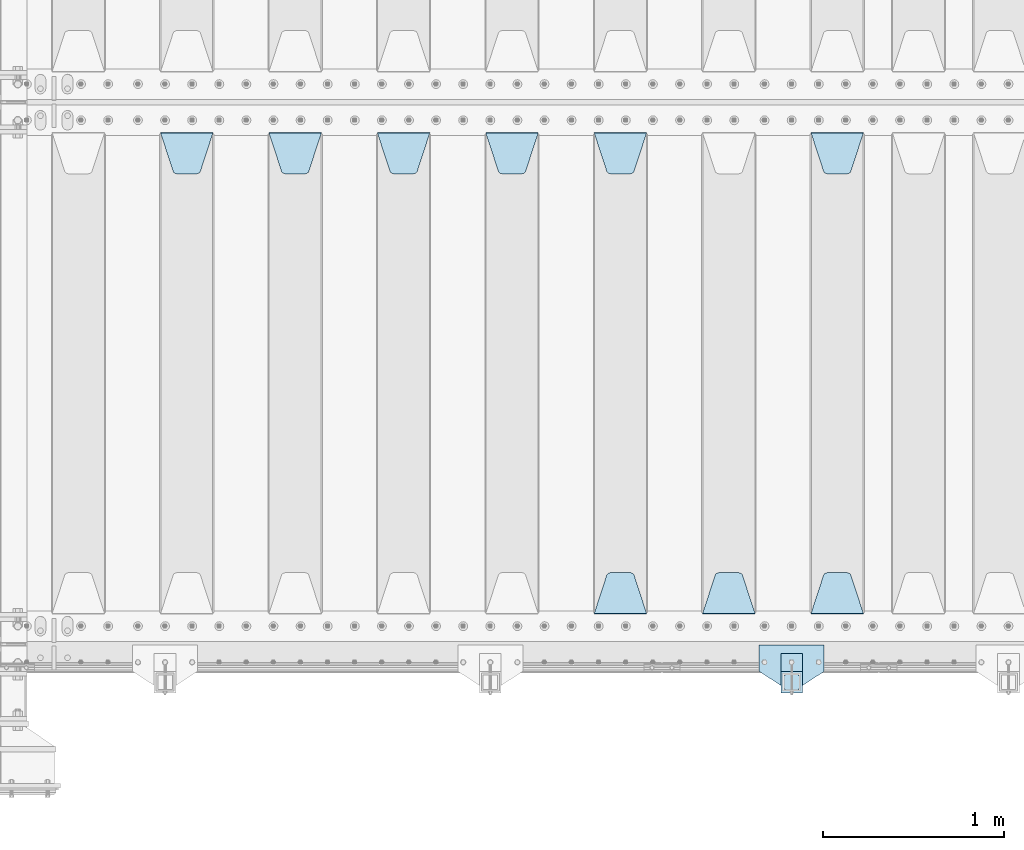
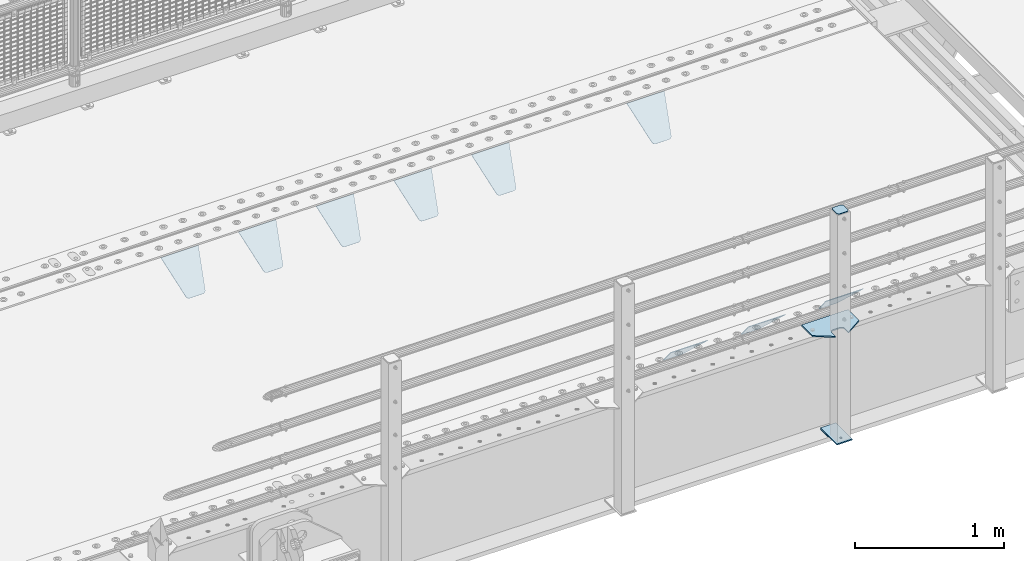
# One storey, part 218 of 242: 13 plates.
"""IFC2X3 building model written with IfcOpenShell, lengths in millimetres."""

from ifc_helpers import new_model, si_unit, frame, origin_with_axes, place, context, subcontext, project, spatial, faceted_brep, material, type_object, element, save


model = new_model("IFC2X3")

# Units and contexts
model_context = context("Model", 3, precision=1e-05, world=origin_with_axes())
body_context = subcontext(model_context, "Body", "Model", "MODEL_VIEW")
ifc_project = project(units=[si_unit("LENGTHUNIT", "METRE", prefix="MILLI"), si_unit("AREAUNIT", "SQUARE_METRE"), si_unit("VOLUMEUNIT", "CUBIC_METRE"), si_unit("MASSUNIT", "GRAM", prefix="KILO"), si_unit("TIMEUNIT", "SECOND"), si_unit("PLANEANGLEUNIT", "RADIAN"), si_unit("SOLIDANGLEUNIT", "STERADIAN"), si_unit("THERMODYNAMICTEMPERATUREUNIT", "DEGREE_CELSIUS"), si_unit("LUMINOUSINTENSITYUNIT", "LUMEN")], contexts=[model_context])

# Site, building, storey
site_placement = place(None, origin_with_axes())
site = spatial("IfcSite", under=ifc_project, at=site_placement, CompositionType="ELEMENT")
building_placement = place(site_placement, origin_with_axes())
building = spatial("IfcBuilding", under=site, at=building_placement, Name="Standard", CompositionType="ELEMENT")
storey_placement = place(building_placement, origin_with_axes())
storey = spatial("IfcBuildingStorey", under=building, at=storey_placement, Name="Undefined", CompositionType="ELEMENT", Elevation=0.0)

# Plates
ifc_material_1 = material(Name="STEEL/S355J2")
plate_type_1 = type_object("IfcPlateType", PredefinedType="NOTDEFINED")
plate_1_placement = place(storey_placement, frame((-23852.0, -24005.0, 5.00000000004911), z_axis=(0.0, -1.0, 0.0), x_axis=(-1.0, 0.0, 0.0)))
element("IfcPlate", 1, at=plate_1_placement, inside=storey, type_object=plate_type_1, material=ifc_material_1, context=body_context, shape_type="Brep", body=[
    faceted_brep([(0.0, -5.0, 0.0), (2.31396552408114e-06, -5.0, 145.0), (2.31396552408114e-06, 5.0, 145.0), (0.0, 5.0, 0.0), (130.0, -5.0, 230.0), (130.0, 5.0, 230.0), (130.0, -5.0, 180.0), (130.0, 5.0, 180.0), (130.48036798992, -5.0, 175.122741949595), (130.48036798992, 5.0, 175.122741949595), (131.903011687216, -5.0, 170.432914190871), (131.903011687216, 5.0, 170.432914190871), (134.213259692435, -5.0, 166.110744174512), (134.213259692435, 5.0, 166.110744174512), (137.322330470335, -5.0, 162.322330470335), (137.322330470335, 5.0, 162.322330470335), (141.110744174512, -5.0, 159.213259692435), (141.110744174512, 5.0, 159.213259692435), (145.432914190871, -5.0, 156.903011687216), (145.432914190871, 5.0, 156.903011687216), (150.122741949595, -5.0, 155.48036798992), (150.122741949595, 5.0, 155.48036798992), (155.0, -5.0, 155.0), (155.0, 5.0, 155.0), (205.0, -5.0, 155.0), (205.0, 5.0, 155.0), (209.877258050405, -5.0, 155.48036798992), (209.877258050405, 5.0, 155.48036798992), (214.567085809129, -5.0, 156.903011687216), (214.567085809129, 5.0, 156.903011687216), (218.889255825488, -5.0, 159.213259692435), (218.889255825488, 5.0, 159.213259692435), (222.677669529665, -5.0, 162.322330470335), (222.677669529665, 5.0, 162.322330470335), (225.786740307565, -5.0, 166.110744174512), (225.786740307565, 5.0, 166.110744174512), (228.096988312784, -5.0, 170.432914190871), (228.096988312784, 5.0, 170.432914190871), (229.51963201008, -5.0, 175.122741949595), (229.51963201008, 5.0, 175.122741949595), (230.0, -5.0, 180.0), (230.0, 5.0, 180.0), (230.0, -5.0, 230.0), (230.0, 5.0, 230.0), (360.0, -5.0, 145.0), (360.0, 5.0, 145.0), (360.0, -5.0, -7.27595761418343e-12), (360.0, 5.0, -7.27595761418343e-12)], [[[0, 1, 2, 3]], [[1, 4, 5, 2]], [[4, 6, 7, 5]], [[6, 8, 9, 7]], [[8, 10, 11, 9]], [[10, 12, 13, 11]], [[12, 14, 15, 13]], [[14, 16, 17, 15]], [[16, 18, 19, 17]], [[18, 20, 21, 19]], [[20, 22, 23, 21]], [[22, 24, 25, 23]], [[24, 26, 27, 25]], [[26, 28, 29, 27]], [[28, 30, 31, 29]], [[30, 32, 33, 31]], [[32, 34, 35, 33]], [[34, 36, 37, 35]], [[36, 38, 39, 37]], [[38, 40, 41, 39]], [[40, 42, 43, 41]], [[42, 44, 45, 43]], [[44, 46, 47, 45]], [[46, 0, 3, 47]], [[5, 7, 9, 11, 13, 15, 17, 19, 21, 23, 25, 27, 29, 31, 33, 35, 37, 39, 41, 43, 45, 47, 3, 2]], [[46, 44, 42, 40, 38, 36, 34, 32, 30, 28, 26, 24, 22, 20, 18, 16, 14, 12, 10, 8, 6, 4, 1, 0]]]),
])
plate_type_2 = type_object("IfcPlateType", PredefinedType="NOTDEFINED")
plate_2_placement = place(storey_placement, frame((-23972.0000000001, -24050.0000000002, -850.000000000002), z_axis=(0.0, -1.0, 0.0), x_axis=(-1.0, 0.0, 0.0)))
element("IfcPlate", 2, at=plate_2_placement, inside=storey, type_object=plate_type_2, material=ifc_material_1, context=body_context, shape_type="Brep", body=[
    faceted_brep([(53.6360389691836, -5.0, 176.363961030471), (53.6360389691836, 5.0, 176.363961030471), (59.9999999998618, 5.0, 178.999999999793), (59.9999999998618, -5.0, 178.999999999793), (66.3639610305399, 5.0, 176.363961030471), (66.3639610305399, -5.0, 176.363961030471), (68.9999999998618, 5.0, 169.999999999793), (68.9999999998618, -5.0, 169.999999999793), (66.3639610305399, 5.0, 163.636038969114), (66.3639610305399, -5.0, 163.636038969114), (59.9999999998618, 5.0, 160.999999999793), (59.9999999998618, -5.0, 160.999999999793), (53.6360389691836, 5.0, 163.636038969114), (53.6360389691836, -5.0, 163.636038969114), (50.9999999998618, 5.0, 169.999999999793), (50.9999999998618, -5.0, 169.999999999793), (120.0, -5.0, 0.0), (120.0, -5.0, 220.0), (0.0, -5.0, 220.0), (0.0, -5.0, 0.0), (0.0, 5.0, 0.0), (120.0, 5.0, 0.0), (120.0, 5.0, 220.0), (0.0, 5.0, 220.0)], [[[0, 1, 2, 3]], [[3, 2, 4, 5]], [[5, 4, 6, 7]], [[7, 6, 8, 9]], [[9, 8, 10, 11]], [[11, 10, 12, 13]], [[13, 12, 14, 15]], [[15, 14, 1, 0]], [[16, 17, 18, 19], [3, 5, 7, 9, 11, 13, 15, 0]], [[16, 19, 20, 21]], [[17, 16, 21, 22]], [[18, 17, 22, 23]], [[19, 18, 23, 20]], [[22, 21, 20, 23], [10, 8, 6, 4, 2, 1, 14, 12]]]),
])
plate_type_3 = type_object("IfcPlateType", PredefinedType="NOTDEFINED")
plate_3_placement = place(storey_placement, frame((-24076.0000000001, -24166.0000000002, 1012.50000000001), z_axis=(0.0, -1.0, 0.0), x_axis=(1.0, 0.0, 0.0)))
element("IfcPlate", 3, at=plate_3_placement, inside=storey, type_object=plate_type_3, material=ifc_material_1, context=body_context, shape_type="Brep", body=[
    faceted_brep([(0.0, -2.5, 19.0), (0.0, -2.5, 69.0), (0.0, 2.5, 69.0), (0.0, 2.5, 19.0), (0.476369668544066, -2.5, 73.2278977451715), (0.476369668544066, 2.5, 73.2278977451715), (1.88159150985302, -2.5, 77.2437910432345), (1.88159150985302, 2.5, 77.2437910432345), (4.14520183310742, -2.5, 80.8463062353148), (4.14520183310742, 2.5, 80.8463062353148), (7.15369376468516, -2.5, 83.8547981668926), (7.15369376468516, 2.5, 83.8547981668926), (10.7562089567655, -2.5, 86.118408490147), (10.7562089567655, 2.5, 86.118408490147), (14.7721022548285, -2.5, 87.5236303314559), (14.7721022548285, 2.5, 87.5236303314559), (19.0, -2.5, 88.0), (19.0, 2.5, 88.0), (69.0, -2.5, 88.0), (69.0, 2.5, 88.0), (73.2278977451715, -2.5, 87.5236303314559), (73.2278977451715, 2.5, 87.5236303314559), (77.2437910432345, -2.5, 86.118408490147), (77.2437910432345, 2.5, 86.118408490147), (80.8463062353148, -2.5, 83.8547981668926), (80.8463062353148, 2.5, 83.8547981668926), (83.8547981668926, -2.5, 80.8463062353148), (83.8547981668926, 2.5, 80.8463062353148), (86.118408490147, -2.5, 77.2437910432345), (86.118408490147, 2.5, 77.2437910432345), (87.5236303314559, -2.5, 73.2278977451715), (87.5236303314559, 2.5, 73.2278977451715), (88.0, -2.5, 69.0), (88.0, 2.5, 69.0), (88.0, -2.5, 19.0), (88.0, 2.5, 19.0), (87.5236303314559, -2.5, 14.7721022548285), (87.5236303314559, 2.5, 14.7721022548285), (86.118408490147, -2.5, 10.7562089567655), (86.118408490147, 2.5, 10.7562089567655), (83.8547981668926, -2.5, 7.15369376468516), (83.8547981668926, 2.5, 7.15369376468516), (80.8463062353148, -2.5, 4.14520183310742), (80.8463062353148, 2.5, 4.14520183310742), (77.2437910432345, -2.5, 1.88159150985302), (77.2437910432345, 2.5, 1.88159150985302), (73.2278977451715, -2.5, 0.476369668544066), (73.2278977451715, 2.5, 0.476369668544066), (69.0, -2.5, 0.0), (69.0, 2.5, 0.0), (19.0, -2.5, 0.0), (19.0, 2.5, 0.0), (14.7721022548285, -2.5, 0.476369668544066), (14.7721022548285, 2.5, 0.476369668544066), (10.7562089567655, -2.5, 1.88159150985302), (10.7562089567655, 2.5, 1.88159150985302), (7.15369376468516, -2.5, 4.14520183310742), (7.15369376468516, 2.5, 4.14520183310742), (4.14520183310742, -2.5, 7.15369376468516), (4.14520183310742, 2.5, 7.15369376468516), (1.88159150985302, -2.5, 10.7562089567655), (1.88159150985302, 2.5, 10.7562089567655), (0.476369668544066, -2.5, 14.7721022548285), (0.476369668544066, 2.5, 14.7721022548285)], [[[0, 1, 2, 3]], [[1, 4, 5, 2]], [[4, 6, 7, 5]], [[6, 8, 9, 7]], [[8, 10, 11, 9]], [[10, 12, 13, 11]], [[12, 14, 15, 13]], [[14, 16, 17, 15]], [[16, 18, 19, 17]], [[18, 20, 21, 19]], [[20, 22, 23, 21]], [[22, 24, 25, 23]], [[24, 26, 27, 25]], [[26, 28, 29, 27]], [[28, 30, 31, 29]], [[30, 32, 33, 31]], [[32, 34, 35, 33]], [[34, 36, 37, 35]], [[36, 38, 39, 37]], [[38, 40, 41, 39]], [[40, 42, 43, 41]], [[42, 44, 45, 43]], [[44, 46, 47, 45]], [[46, 48, 49, 47]], [[48, 50, 51, 49]], [[50, 52, 53, 51]], [[52, 54, 55, 53]], [[54, 56, 57, 55]], [[56, 58, 59, 57]], [[58, 60, 61, 59]], [[60, 62, 63, 61]], [[62, 0, 3, 63]], [[5, 7, 9, 11, 13, 15, 17, 19, 21, 23, 25, 27, 29, 31, 33, 35, 37, 39, 41, 43, 45, 47, 49, 51, 53, 55, 57, 59, 61, 63, 3, 2]], [[62, 60, 58, 56, 54, 52, 50, 48, 46, 44, 42, 40, 38, 36, 34, 32, 30, 28, 26, 24, 22, 20, 18, 16, 14, 12, 10, 8, 6, 4, 1, 0]]]),
])
plate_type_4 = type_object("IfcPlateType", PredefinedType="NOTDEFINED")
plate_4_placement = place(storey_placement, frame((-23972.0000000001, -24050.0000000002, -857.500000000002), z_axis=(0.0, -1.0, 0.0), x_axis=(-1.0, 0.0, 0.0)))
element("IfcPlate", 4, at=plate_4_placement, inside=storey, type_object=plate_type_4, material=ifc_material_1, context=body_context, shape_type="Brep", body=[
    faceted_brep([(0.0, -2.5, 0.0), (0.0, -2.5, 100.0), (0.0, 2.5, 100.0), (0.0, 2.5, 0.0), (120.0, -2.5, 100.0), (120.0, 2.5, 100.0), (120.0, -2.5, 0.0), (120.0, 2.5, 0.0)], [[[0, 1, 2, 3]], [[1, 4, 5, 2]], [[4, 6, 7, 5]], [[6, 0, 3, 7]], [[5, 7, 3, 2]], [[6, 4, 1, 0]]]),
])
ifc_material_2 = material(Name="STEEL/S355N")
plate_type_5 = type_object("IfcPlateType", PredefinedType="NOTDEFINED")
plate_5_placement = place(storey_placement, frame((-23925.0, -21168.232233044, -1.76776695296576), z_axis=(0.0, -0.707106781186547, -0.707106781186548), x_axis=(1.0, 0.0, 0.0)))
element("IfcPlate", 5, at=plate_5_placement, inside=storey, type_object=plate_type_5, material=ifc_material_2, context=body_context, shape_type="Brep", body=[
    faceted_brep([(0.0, -2.5, 0.0), (69.345504679477, -2.50000000000182, 300.171731424829), (69.345504679477, 2.5, 300.171731424829), (0.0, 2.5, 0.0), (70.9274061199576, -2.5, 304.897442415398), (70.9274061199576, 2.5, 304.897442415398), (73.3818627772307, -2.5, 309.234538108525), (73.3818627772307, 2.50000000000182, 309.234538108529), (76.6187032999551, -2.5, 313.023683126101), (76.6187032999551, 2.50000000000182, 313.023683126103), (80.5190132704993, -2.5, 316.12567259537), (80.5190132704993, 2.5, 316.12567259537), (84.9395038596849, -2.5, 318.426546230474), (84.9395038596849, 2.50000000000182, 318.426546230476), (89.7177759439219, -2.49999999999818, 319.841774983273), (89.7177759439219, 2.50000000000182, 319.841774983273), (94.678286292652, -2.5, 320.319366455076), (94.678286292652, 2.5, 320.319366455076), (195.321713707348, -2.5, 320.319366455076), (195.321713707348, 2.5, 320.319366455076), (200.282224056078, -2.5, 319.841774983272), (200.282224056078, 2.50000000000182, 319.841774983273), (205.060496140315, -2.5, 318.426546230474), (205.060496140315, 2.49999999999818, 318.426546230474), (209.480986729501, -2.49999999999818, 316.12567259537), (209.480986729501, 2.5, 316.12567259537), (213.381296700045, -2.5, 313.023683126101), (213.381296700045, 2.49999999999818, 313.023683126101), (216.618137222769, -2.5, 309.234538108525), (216.618137222769, 2.5, 309.234538108523), (219.072593880042, -2.49999999999818, 304.897442415398), (219.072593880042, 2.50000000000182, 304.897442415398), (220.654495320523, -2.50000000000182, 300.171731424829), (220.654495320523, 2.5, 300.171731424829), (290.0, -2.5, 0.0), (290.0, 2.5, -1.81898940354586e-12)], [[[0, 1, 2, 3]], [[1, 4, 5, 2]], [[4, 6, 7, 5]], [[6, 8, 9, 7]], [[8, 10, 11, 9]], [[10, 12, 13, 11]], [[12, 14, 15, 13]], [[14, 16, 17, 15]], [[16, 18, 19, 17]], [[18, 20, 21, 19]], [[20, 22, 23, 21]], [[22, 24, 25, 23]], [[24, 26, 27, 25]], [[26, 28, 29, 27]], [[28, 30, 31, 29]], [[30, 32, 33, 31]], [[32, 34, 35, 33]], [[34, 0, 3, 35]], [[5, 7, 9, 11, 13, 15, 17, 19, 21, 23, 25, 27, 29, 31, 33, 35, 3, 2]], [[34, 32, 30, 28, 26, 24, 22, 20, 18, 16, 14, 12, 10, 8, 6, 4, 1, 0]]]),
])
plate_6_placement = place(storey_placement, frame((-23635.0, -23831.767766953, -1.76776695296758), z_axis=(0.0, 0.707106781186547, -0.707106781186548), x_axis=(-1.0, 0.0, 0.0)))
element("IfcPlate", 6, at=plate_6_placement, inside=storey, type_object=plate_type_5, material=ifc_material_2, context=body_context, shape_type="Brep", body=[
    faceted_brep([(0.0, -2.5, 0.0), (69.345504679477, -2.50000000000182, 300.171731424829), (69.345504679477, 2.5, 300.171731424829), (0.0, 2.5, 0.0), (70.9274061199576, -2.5, 304.897442415398), (70.9274061199576, 2.5, 304.897442415398), (73.3818627772307, -2.5, 309.234538108525), (73.3818627772307, 2.50000000000182, 309.234538108529), (76.6187032999551, -2.5, 313.023683126101), (76.6187032999551, 2.50000000000182, 313.023683126103), (80.5190132704993, -2.5, 316.12567259537), (80.5190132704993, 2.5, 316.12567259537), (84.9395038596849, -2.5, 318.426546230474), (84.9395038596849, 2.50000000000182, 318.426546230476), (89.7177759439219, -2.49999999999818, 319.841774983273), (89.7177759439219, 2.50000000000182, 319.841774983273), (94.678286292652, -2.5, 320.319366455076), (94.678286292652, 2.5, 320.319366455076), (195.321713707348, -2.5, 320.319366455076), (195.321713707348, 2.5, 320.319366455076), (200.282224056078, -2.5, 319.841774983272), (200.282224056078, 2.50000000000182, 319.841774983273), (205.060496140315, -2.5, 318.426546230474), (205.060496140315, 2.49999999999818, 318.426546230474), (209.480986729501, -2.49999999999818, 316.12567259537), (209.480986729501, 2.5, 316.12567259537), (213.381296700045, -2.5, 313.023683126101), (213.381296700045, 2.49999999999818, 313.023683126101), (216.618137222769, -2.5, 309.234538108525), (216.618137222769, 2.5, 309.234538108523), (219.072593880042, -2.49999999999818, 304.897442415398), (219.072593880042, 2.50000000000182, 304.897442415398), (220.654495320523, -2.50000000000182, 300.171731424829), (220.654495320523, 2.5, 300.171731424829), (290.0, -2.5, 0.0), (290.0, 2.5, -1.81898940354586e-12)], [[[0, 1, 2, 3]], [[1, 4, 5, 2]], [[4, 6, 7, 5]], [[6, 8, 9, 7]], [[8, 10, 11, 9]], [[10, 12, 13, 11]], [[12, 14, 15, 13]], [[14, 16, 17, 15]], [[16, 18, 19, 17]], [[18, 20, 21, 19]], [[20, 22, 23, 21]], [[22, 24, 25, 23]], [[24, 26, 27, 25]], [[26, 28, 29, 27]], [[28, 30, 31, 29]], [[30, 32, 33, 31]], [[32, 34, 35, 33]], [[34, 0, 3, 35]], [[5, 7, 9, 11, 13, 15, 17, 19, 21, 23, 25, 27, 29, 31, 33, 35, 3, 2]], [[34, 32, 30, 28, 26, 24, 22, 20, 18, 16, 14, 12, 10, 8, 6, 4, 1, 0]]]),
])
plate_7_placement = place(storey_placement, frame((-24235.0, -23831.767766953, -1.76776695296758), z_axis=(0.0, 0.707106781186547, -0.707106781186548), x_axis=(-1.0, 0.0, 0.0)))
element("IfcPlate", 7, at=plate_7_placement, inside=storey, type_object=plate_type_5, material=ifc_material_2, context=body_context, shape_type="Brep", body=[
    faceted_brep([(0.0, -2.5, 0.0), (69.345504679477, -2.50000000000182, 300.171731424829), (69.345504679477, 2.5, 300.171731424829), (0.0, 2.5, 0.0), (70.9274061199576, -2.5, 304.897442415398), (70.9274061199576, 2.5, 304.897442415398), (73.3818627772307, -2.5, 309.234538108525), (73.3818627772307, 2.50000000000182, 309.234538108529), (76.6187032999551, -2.5, 313.023683126101), (76.6187032999551, 2.50000000000182, 313.023683126103), (80.5190132704993, -2.5, 316.12567259537), (80.5190132704993, 2.5, 316.12567259537), (84.9395038596849, -2.5, 318.426546230474), (84.9395038596849, 2.50000000000182, 318.426546230476), (89.7177759439219, -2.49999999999818, 319.841774983273), (89.7177759439219, 2.50000000000182, 319.841774983273), (94.678286292652, -2.5, 320.319366455076), (94.678286292652, 2.5, 320.319366455076), (195.321713707348, -2.5, 320.319366455076), (195.321713707348, 2.5, 320.319366455076), (200.282224056078, -2.5, 319.841774983272), (200.282224056078, 2.50000000000182, 319.841774983273), (205.060496140315, -2.5, 318.426546230474), (205.060496140315, 2.49999999999818, 318.426546230474), (209.480986729501, -2.49999999999818, 316.12567259537), (209.480986729501, 2.5, 316.12567259537), (213.381296700045, -2.5, 313.023683126101), (213.381296700045, 2.49999999999818, 313.023683126101), (216.618137222769, -2.5, 309.234538108525), (216.618137222769, 2.5, 309.234538108523), (219.072593880042, -2.49999999999818, 304.897442415398), (219.072593880042, 2.50000000000182, 304.897442415398), (220.654495320523, -2.50000000000182, 300.171731424829), (220.654495320523, 2.5, 300.171731424829), (290.0, -2.5, 0.0), (290.0, 2.5, -1.81898940354586e-12)], [[[0, 1, 2, 3]], [[1, 4, 5, 2]], [[4, 6, 7, 5]], [[6, 8, 9, 7]], [[8, 10, 11, 9]], [[10, 12, 13, 11]], [[12, 14, 15, 13]], [[14, 16, 17, 15]], [[16, 18, 19, 17]], [[18, 20, 21, 19]], [[20, 22, 23, 21]], [[22, 24, 25, 23]], [[24, 26, 27, 25]], [[26, 28, 29, 27]], [[28, 30, 31, 29]], [[30, 32, 33, 31]], [[32, 34, 35, 33]], [[34, 0, 3, 35]], [[5, 7, 9, 11, 13, 15, 17, 19, 21, 23, 25, 27, 29, 31, 33, 35, 3, 2]], [[34, 32, 30, 28, 26, 24, 22, 20, 18, 16, 14, 12, 10, 8, 6, 4, 1, 0]]]),
])
plate_8_placement = place(storey_placement, frame((-25125.0, -21168.232233044, -1.76776695296576), z_axis=(0.0, -0.707106781186547, -0.707106781186548), x_axis=(1.0, 0.0, 0.0)))
element("IfcPlate", 8, at=plate_8_placement, inside=storey, type_object=plate_type_5, material=ifc_material_2, context=body_context, shape_type="Brep", body=[
    faceted_brep([(0.0, -2.5, 0.0), (69.345504679477, -2.50000000000182, 300.171731424829), (69.345504679477, 2.5, 300.171731424829), (0.0, 2.5, 0.0), (70.9274061199576, -2.5, 304.897442415398), (70.9274061199576, 2.5, 304.897442415398), (73.3818627772307, -2.5, 309.234538108525), (73.3818627772307, 2.50000000000182, 309.234538108529), (76.6187032999551, -2.5, 313.023683126101), (76.6187032999551, 2.50000000000182, 313.023683126103), (80.5190132704993, -2.5, 316.12567259537), (80.5190132704993, 2.5, 316.12567259537), (84.9395038596849, -2.5, 318.426546230474), (84.9395038596849, 2.50000000000182, 318.426546230476), (89.7177759439219, -2.49999999999818, 319.841774983273), (89.7177759439219, 2.50000000000182, 319.841774983273), (94.678286292652, -2.5, 320.319366455076), (94.678286292652, 2.5, 320.319366455076), (195.321713707348, -2.5, 320.319366455076), (195.321713707348, 2.5, 320.319366455076), (200.282224056078, -2.5, 319.841774983272), (200.282224056078, 2.50000000000182, 319.841774983273), (205.060496140315, -2.5, 318.426546230474), (205.060496140315, 2.49999999999818, 318.426546230474), (209.480986729501, -2.49999999999818, 316.12567259537), (209.480986729501, 2.5, 316.12567259537), (213.381296700045, -2.5, 313.023683126101), (213.381296700045, 2.49999999999818, 313.023683126101), (216.618137222769, -2.5, 309.234538108525), (216.618137222769, 2.5, 309.234538108523), (219.072593880042, -2.49999999999818, 304.897442415398), (219.072593880042, 2.50000000000182, 304.897442415398), (220.654495320523, -2.50000000000182, 300.171731424829), (220.654495320523, 2.5, 300.171731424829), (290.0, -2.5, 0.0), (290.0, 2.5, -1.81898940354586e-12)], [[[0, 1, 2, 3]], [[1, 4, 5, 2]], [[4, 6, 7, 5]], [[6, 8, 9, 7]], [[8, 10, 11, 9]], [[10, 12, 13, 11]], [[12, 14, 15, 13]], [[14, 16, 17, 15]], [[16, 18, 19, 17]], [[18, 20, 21, 19]], [[20, 22, 23, 21]], [[22, 24, 25, 23]], [[24, 26, 27, 25]], [[26, 28, 29, 27]], [[28, 30, 31, 29]], [[30, 32, 33, 31]], [[32, 34, 35, 33]], [[34, 0, 3, 35]], [[5, 7, 9, 11, 13, 15, 17, 19, 21, 23, 25, 27, 29, 31, 33, 35, 3, 2]], [[34, 32, 30, 28, 26, 24, 22, 20, 18, 16, 14, 12, 10, 8, 6, 4, 1, 0]]]),
])
plate_9_placement = place(storey_placement, frame((-24835.0, -23831.767766953, -1.76776695296758), z_axis=(0.0, 0.707106781186547, -0.707106781186548), x_axis=(-1.0, 0.0, 0.0)))
element("IfcPlate", 9, at=plate_9_placement, inside=storey, type_object=plate_type_5, material=ifc_material_2, context=body_context, shape_type="Brep", body=[
    faceted_brep([(0.0, -2.5, 0.0), (69.345504679477, -2.50000000000182, 300.171731424829), (69.345504679477, 2.5, 300.171731424829), (0.0, 2.5, 0.0), (70.9274061199576, -2.5, 304.897442415398), (70.9274061199576, 2.5, 304.897442415398), (73.3818627772307, -2.5, 309.234538108525), (73.3818627772307, 2.50000000000182, 309.234538108529), (76.6187032999551, -2.5, 313.023683126101), (76.6187032999551, 2.50000000000182, 313.023683126103), (80.5190132704993, -2.5, 316.12567259537), (80.5190132704993, 2.5, 316.12567259537), (84.9395038596849, -2.5, 318.426546230474), (84.9395038596849, 2.50000000000182, 318.426546230476), (89.7177759439219, -2.49999999999818, 319.841774983273), (89.7177759439219, 2.50000000000182, 319.841774983273), (94.678286292652, -2.5, 320.319366455076), (94.678286292652, 2.5, 320.319366455076), (195.321713707348, -2.5, 320.319366455076), (195.321713707348, 2.5, 320.319366455076), (200.282224056078, -2.5, 319.841774983272), (200.282224056078, 2.50000000000182, 319.841774983273), (205.060496140315, -2.5, 318.426546230474), (205.060496140315, 2.49999999999818, 318.426546230474), (209.480986729501, -2.49999999999818, 316.12567259537), (209.480986729501, 2.5, 316.12567259537), (213.381296700045, -2.5, 313.023683126101), (213.381296700045, 2.49999999999818, 313.023683126101), (216.618137222769, -2.5, 309.234538108525), (216.618137222769, 2.5, 309.234538108523), (219.072593880042, -2.49999999999818, 304.897442415398), (219.072593880042, 2.50000000000182, 304.897442415398), (220.654495320523, -2.50000000000182, 300.171731424829), (220.654495320523, 2.5, 300.171731424829), (290.0, -2.5, 0.0), (290.0, 2.5, -1.81898940354586e-12)], [[[0, 1, 2, 3]], [[1, 4, 5, 2]], [[4, 6, 7, 5]], [[6, 8, 9, 7]], [[8, 10, 11, 9]], [[10, 12, 13, 11]], [[12, 14, 15, 13]], [[14, 16, 17, 15]], [[16, 18, 19, 17]], [[18, 20, 21, 19]], [[20, 22, 23, 21]], [[22, 24, 25, 23]], [[24, 26, 27, 25]], [[26, 28, 29, 27]], [[28, 30, 31, 29]], [[30, 32, 33, 31]], [[32, 34, 35, 33]], [[34, 0, 3, 35]], [[5, 7, 9, 11, 13, 15, 17, 19, 21, 23, 25, 27, 29, 31, 33, 35, 3, 2]], [[34, 32, 30, 28, 26, 24, 22, 20, 18, 16, 14, 12, 10, 8, 6, 4, 1, 0]]]),
])
plate_10_placement = place(storey_placement, frame((-25725.0, -21168.232233044, -1.76776695296576), z_axis=(0.0, -0.707106781186547, -0.707106781186548), x_axis=(1.0, 0.0, 0.0)))
element("IfcPlate", 10, at=plate_10_placement, inside=storey, type_object=plate_type_5, material=ifc_material_2, context=body_context, shape_type="Brep", body=[
    faceted_brep([(0.0, -2.5, 0.0), (69.345504679477, -2.50000000000182, 300.171731424829), (69.345504679477, 2.5, 300.171731424829), (0.0, 2.5, 0.0), (70.9274061199576, -2.5, 304.897442415398), (70.9274061199576, 2.5, 304.897442415398), (73.3818627772307, -2.5, 309.234538108525), (73.3818627772307, 2.50000000000182, 309.234538108529), (76.6187032999551, -2.5, 313.023683126101), (76.6187032999551, 2.50000000000182, 313.023683126103), (80.5190132704993, -2.5, 316.12567259537), (80.5190132704993, 2.5, 316.12567259537), (84.9395038596849, -2.5, 318.426546230474), (84.9395038596849, 2.50000000000182, 318.426546230476), (89.7177759439219, -2.49999999999818, 319.841774983273), (89.7177759439219, 2.50000000000182, 319.841774983273), (94.678286292652, -2.5, 320.319366455076), (94.678286292652, 2.5, 320.319366455076), (195.321713707348, -2.5, 320.319366455076), (195.321713707348, 2.5, 320.319366455076), (200.282224056078, -2.5, 319.841774983272), (200.282224056078, 2.50000000000182, 319.841774983273), (205.060496140315, -2.5, 318.426546230474), (205.060496140315, 2.49999999999818, 318.426546230474), (209.480986729501, -2.49999999999818, 316.12567259537), (209.480986729501, 2.5, 316.12567259537), (213.381296700045, -2.5, 313.023683126101), (213.381296700045, 2.49999999999818, 313.023683126101), (216.618137222769, -2.5, 309.234538108525), (216.618137222769, 2.5, 309.234538108523), (219.072593880042, -2.49999999999818, 304.897442415398), (219.072593880042, 2.50000000000182, 304.897442415398), (220.654495320523, -2.50000000000182, 300.171731424829), (220.654495320523, 2.5, 300.171731424829), (290.0, -2.5, 0.0), (290.0, 2.5, -1.81898940354586e-12)], [[[0, 1, 2, 3]], [[1, 4, 5, 2]], [[4, 6, 7, 5]], [[6, 8, 9, 7]], [[8, 10, 11, 9]], [[10, 12, 13, 11]], [[12, 14, 15, 13]], [[14, 16, 17, 15]], [[16, 18, 19, 17]], [[18, 20, 21, 19]], [[20, 22, 23, 21]], [[22, 24, 25, 23]], [[24, 26, 27, 25]], [[26, 28, 29, 27]], [[28, 30, 31, 29]], [[30, 32, 33, 31]], [[32, 34, 35, 33]], [[34, 0, 3, 35]], [[5, 7, 9, 11, 13, 15, 17, 19, 21, 23, 25, 27, 29, 31, 33, 35, 3, 2]], [[34, 32, 30, 28, 26, 24, 22, 20, 18, 16, 14, 12, 10, 8, 6, 4, 1, 0]]]),
])
plate_11_placement = place(storey_placement, frame((-26325.0, -21168.232233044, -1.76776695296576), z_axis=(0.0, -0.707106781186547, -0.707106781186548), x_axis=(1.0, 0.0, 0.0)))
element("IfcPlate", 11, at=plate_11_placement, inside=storey, type_object=plate_type_5, material=ifc_material_2, context=body_context, shape_type="Brep", body=[
    faceted_brep([(0.0, -2.5, 0.0), (69.345504679477, -2.50000000000182, 300.171731424829), (69.345504679477, 2.5, 300.171731424829), (0.0, 2.5, 0.0), (70.9274061199576, -2.5, 304.897442415398), (70.9274061199576, 2.5, 304.897442415398), (73.3818627772307, -2.5, 309.234538108525), (73.3818627772307, 2.50000000000182, 309.234538108529), (76.6187032999551, -2.5, 313.023683126101), (76.6187032999551, 2.50000000000182, 313.023683126103), (80.5190132704993, -2.5, 316.12567259537), (80.5190132704993, 2.5, 316.12567259537), (84.9395038596849, -2.5, 318.426546230474), (84.9395038596849, 2.50000000000182, 318.426546230476), (89.7177759439219, -2.49999999999818, 319.841774983273), (89.7177759439219, 2.50000000000182, 319.841774983273), (94.678286292652, -2.5, 320.319366455076), (94.678286292652, 2.5, 320.319366455076), (195.321713707348, -2.5, 320.319366455076), (195.321713707348, 2.5, 320.319366455076), (200.282224056078, -2.5, 319.841774983272), (200.282224056078, 2.50000000000182, 319.841774983273), (205.060496140315, -2.5, 318.426546230474), (205.060496140315, 2.49999999999818, 318.426546230474), (209.480986729501, -2.49999999999818, 316.12567259537), (209.480986729501, 2.5, 316.12567259537), (213.381296700045, -2.5, 313.023683126101), (213.381296700045, 2.49999999999818, 313.023683126101), (216.618137222769, -2.5, 309.234538108525), (216.618137222769, 2.5, 309.234538108523), (219.072593880042, -2.49999999999818, 304.897442415398), (219.072593880042, 2.50000000000182, 304.897442415398), (220.654495320523, -2.50000000000182, 300.171731424829), (220.654495320523, 2.5, 300.171731424829), (290.0, -2.5, 0.0), (290.0, 2.5, -1.81898940354586e-12)], [[[0, 1, 2, 3]], [[1, 4, 5, 2]], [[4, 6, 7, 5]], [[6, 8, 9, 7]], [[8, 10, 11, 9]], [[10, 12, 13, 11]], [[12, 14, 15, 13]], [[14, 16, 17, 15]], [[16, 18, 19, 17]], [[18, 20, 21, 19]], [[20, 22, 23, 21]], [[22, 24, 25, 23]], [[24, 26, 27, 25]], [[26, 28, 29, 27]], [[28, 30, 31, 29]], [[30, 32, 33, 31]], [[32, 34, 35, 33]], [[34, 0, 3, 35]], [[5, 7, 9, 11, 13, 15, 17, 19, 21, 23, 25, 27, 29, 31, 33, 35, 3, 2]], [[34, 32, 30, 28, 26, 24, 22, 20, 18, 16, 14, 12, 10, 8, 6, 4, 1, 0]]]),
])
plate_12_placement = place(storey_placement, frame((-26925.0, -21168.232233044, -1.76776695296576), z_axis=(0.0, -0.707106781186547, -0.707106781186548), x_axis=(1.0, 0.0, 0.0)))
element("IfcPlate", 12, at=plate_12_placement, inside=storey, type_object=plate_type_5, material=ifc_material_2, context=body_context, shape_type="Brep", body=[
    faceted_brep([(0.0, -2.5, 0.0), (69.345504679477, -2.50000000000182, 300.171731424829), (69.345504679477, 2.5, 300.171731424829), (0.0, 2.5, 0.0), (70.9274061199576, -2.5, 304.897442415398), (70.9274061199576, 2.5, 304.897442415398), (73.3818627772307, -2.5, 309.234538108525), (73.3818627772307, 2.50000000000182, 309.234538108529), (76.6187032999551, -2.5, 313.023683126101), (76.6187032999551, 2.50000000000182, 313.023683126103), (80.5190132704993, -2.5, 316.12567259537), (80.5190132704993, 2.5, 316.12567259537), (84.9395038596849, -2.5, 318.426546230474), (84.9395038596849, 2.50000000000182, 318.426546230476), (89.7177759439219, -2.49999999999818, 319.841774983273), (89.7177759439219, 2.50000000000182, 319.841774983273), (94.678286292652, -2.5, 320.319366455076), (94.678286292652, 2.5, 320.319366455076), (195.321713707348, -2.5, 320.319366455076), (195.321713707348, 2.5, 320.319366455076), (200.282224056078, -2.5, 319.841774983272), (200.282224056078, 2.50000000000182, 319.841774983273), (205.060496140315, -2.5, 318.426546230474), (205.060496140315, 2.49999999999818, 318.426546230474), (209.480986729501, -2.49999999999818, 316.12567259537), (209.480986729501, 2.5, 316.12567259537), (213.381296700045, -2.5, 313.023683126101), (213.381296700045, 2.49999999999818, 313.023683126101), (216.618137222769, -2.5, 309.234538108525), (216.618137222769, 2.5, 309.234538108523), (219.072593880042, -2.49999999999818, 304.897442415398), (219.072593880042, 2.50000000000182, 304.897442415398), (220.654495320523, -2.50000000000182, 300.171731424829), (220.654495320523, 2.5, 300.171731424829), (290.0, -2.5, 0.0), (290.0, 2.5, -1.81898940354586e-12)], [[[0, 1, 2, 3]], [[1, 4, 5, 2]], [[4, 6, 7, 5]], [[6, 8, 9, 7]], [[8, 10, 11, 9]], [[10, 12, 13, 11]], [[12, 14, 15, 13]], [[14, 16, 17, 15]], [[16, 18, 19, 17]], [[18, 20, 21, 19]], [[20, 22, 23, 21]], [[22, 24, 25, 23]], [[24, 26, 27, 25]], [[26, 28, 29, 27]], [[28, 30, 31, 29]], [[30, 32, 33, 31]], [[32, 34, 35, 33]], [[34, 0, 3, 35]], [[5, 7, 9, 11, 13, 15, 17, 19, 21, 23, 25, 27, 29, 31, 33, 35, 3, 2]], [[34, 32, 30, 28, 26, 24, 22, 20, 18, 16, 14, 12, 10, 8, 6, 4, 1, 0]]]),
])
plate_13_placement = place(storey_placement, frame((-27525.0, -21168.232233044, -1.76776695296576), z_axis=(0.0, -0.707106781186547, -0.707106781186548), x_axis=(1.0, 0.0, 0.0)))
element("IfcPlate", 13, at=plate_13_placement, inside=storey, type_object=plate_type_5, material=ifc_material_2, context=body_context, shape_type="Brep", body=[
    faceted_brep([(0.0, -2.5, 0.0), (69.345504679477, -2.50000000000182, 300.171731424829), (69.345504679477, 2.5, 300.171731424829), (0.0, 2.5, 0.0), (70.9274061199576, -2.5, 304.897442415398), (70.9274061199576, 2.5, 304.897442415398), (73.3818627772307, -2.5, 309.234538108525), (73.3818627772307, 2.50000000000182, 309.234538108529), (76.6187032999551, -2.5, 313.023683126101), (76.6187032999551, 2.50000000000182, 313.023683126103), (80.5190132704993, -2.5, 316.12567259537), (80.5190132704993, 2.5, 316.12567259537), (84.9395038596849, -2.5, 318.426546230474), (84.9395038596849, 2.50000000000182, 318.426546230476), (89.7177759439219, -2.49999999999818, 319.841774983273), (89.7177759439219, 2.50000000000182, 319.841774983273), (94.678286292652, -2.5, 320.319366455076), (94.678286292652, 2.5, 320.319366455076), (195.321713707348, -2.5, 320.319366455076), (195.321713707348, 2.5, 320.319366455076), (200.282224056078, -2.5, 319.841774983272), (200.282224056078, 2.50000000000182, 319.841774983273), (205.060496140315, -2.5, 318.426546230474), (205.060496140315, 2.49999999999818, 318.426546230474), (209.480986729501, -2.49999999999818, 316.12567259537), (209.480986729501, 2.5, 316.12567259537), (213.381296700045, -2.5, 313.023683126101), (213.381296700045, 2.49999999999818, 313.023683126101), (216.618137222769, -2.5, 309.234538108525), (216.618137222769, 2.5, 309.234538108523), (219.072593880042, -2.49999999999818, 304.897442415398), (219.072593880042, 2.50000000000182, 304.897442415398), (220.654495320523, -2.50000000000182, 300.171731424829), (220.654495320523, 2.5, 300.171731424829), (290.0, -2.5, 0.0), (290.0, 2.5, -1.81898940354586e-12)], [[[0, 1, 2, 3]], [[1, 4, 5, 2]], [[4, 6, 7, 5]], [[6, 8, 9, 7]], [[8, 10, 11, 9]], [[10, 12, 13, 11]], [[12, 14, 15, 13]], [[14, 16, 17, 15]], [[16, 18, 19, 17]], [[18, 20, 21, 19]], [[20, 22, 23, 21]], [[22, 24, 25, 23]], [[24, 26, 27, 25]], [[26, 28, 29, 27]], [[28, 30, 31, 29]], [[30, 32, 33, 31]], [[32, 34, 35, 33]], [[34, 0, 3, 35]], [[5, 7, 9, 11, 13, 15, 17, 19, 21, 23, 25, 27, 29, 31, 33, 35, 3, 2]], [[34, 32, 30, 28, 26, 24, 22, 20, 18, 16, 14, 12, 10, 8, 6, 4, 1, 0]]]),
])

save(model, "model.ifc")
